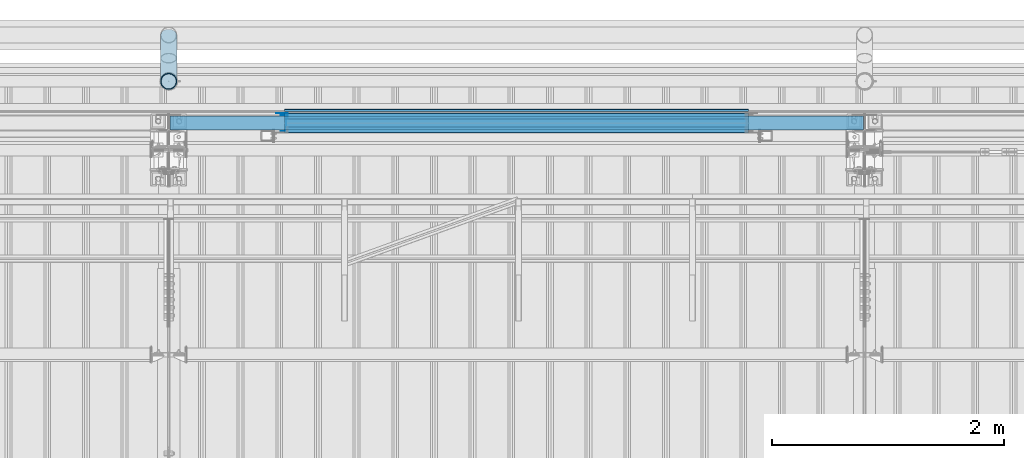
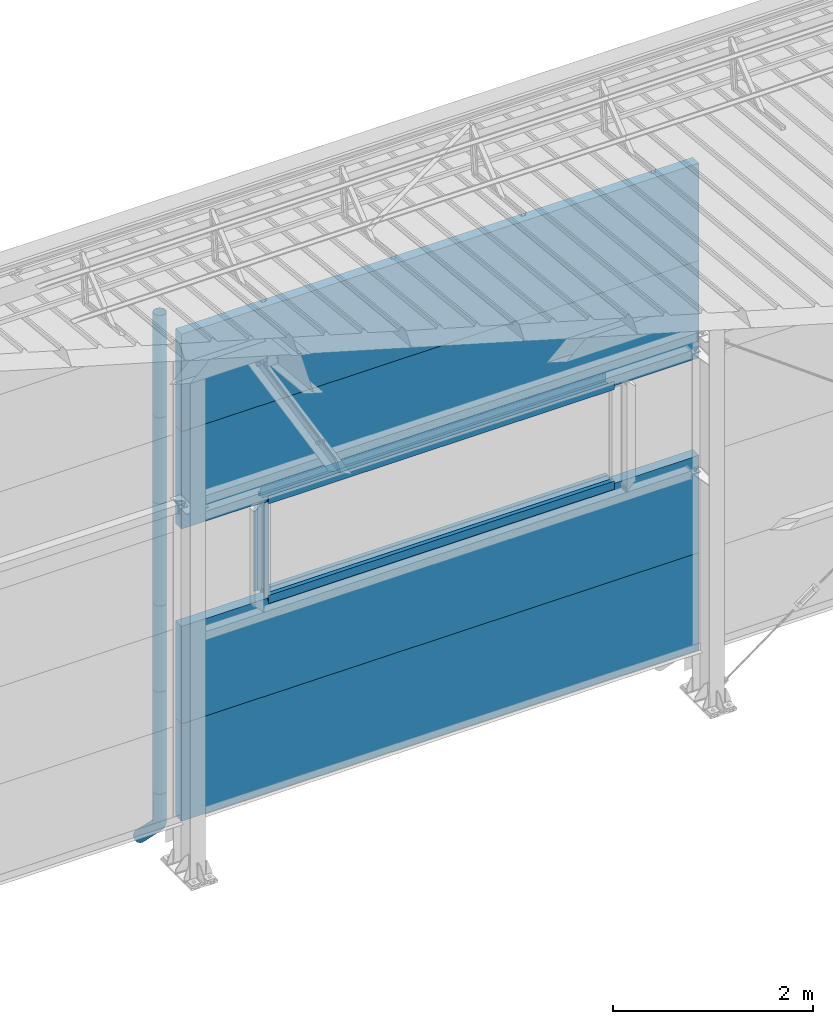
# One storey, part 58 of 709: 19 beams, 19 elements without a shape of their own.
"""IFC4 building model written with IfcOpenShell, lengths in millimetres."""

from ifc_helpers import new_model, entity, si_unit, direction, frame, origin_with_axes, place, context, subcontext, project, spatial, line, indexed_curve, outline, extrude, material, element, aggregate, save


model = new_model("IFC4")

# Units and contexts
model_context = context("Model", 3, precision=0.2, world=origin_with_axes(), true_north=direction((0.0, 1.0)))
body_context = subcontext(model_context, "Body", "Model", "MODEL_VIEW")
ifc_project = project(units=[si_unit("LENGTHUNIT", "METRE", prefix="MILLI"), si_unit("AREAUNIT", "SQUARE_METRE"), si_unit("VOLUMEUNIT", "CUBIC_METRE"), si_unit("MASSUNIT", "GRAM", prefix="KILO"), si_unit("TIMEUNIT", "SECOND"), si_unit("PLANEANGLEUNIT", "RADIAN"), si_unit("SOLIDANGLEUNIT", "STERADIAN"), si_unit("THERMODYNAMICTEMPERATUREUNIT", "DEGREE_CELSIUS"), si_unit("LUMINOUSINTENSITYUNIT", "LUMEN")], contexts=[model_context])

# Site, building, storey
site_placement = place(None, origin_with_axes())
site = spatial("IfcSite", under=ifc_project, at=site_placement, CompositionType="ELEMENT")
building_placement = place(site_placement, origin_with_axes())
building = spatial("IfcBuilding", under=site, at=building_placement, Name="Undefined", CompositionType="ELEMENT")
storey_placement = place(building_placement, origin_with_axes())
storey = spatial("IfcBuildingStorey", under=building, at=storey_placement, Name="Undefined", CompositionType="ELEMENT", Elevation=0.0)

# Assembly, beam
assembly_1_placement = place(storey_placement, frame((16010.0, 22060.0, 895.0), z_axis=(0.0, 0.0, -1.0), x_axis=(1.0, 0.0, 0.0)))
assembly_1 = element("IfcElementAssembly", 1, at=assembly_1_placement, inside=storey)
ifc_material_1 = material(Name="Insulation", Category="Insulation")
beam_1_placement = place(assembly_1_placement, origin_with_axes())
beam_1 = element("IfcBeam", 2, at=beam_1_placement, material=ifc_material_1, ObjectType="P-107", context=body_context, shape_type="SolidModel", body=[
    extrude(outline(indexed_curve([(-595.0, -60.0), (595.0, -60.0), (595.0, 60.0), (-595.0, 60.0)], segments=[line(1, 2, 3, 4, 1)])), frame((0.0, 0.0, 0.0), z_axis=(-1.0, 0.0, 0.0), x_axis=(0.0, 0.0, 1.0)), (0.0, 0.0, -1.0), 5980.0),
])
aggregate(assembly_1, [beam_1])

assembly_2_placement = place(storey_placement, frame((16010.0, 22060.0, 2085.0), z_axis=(0.0, 0.0, -1.0), x_axis=(1.0, 0.0, 0.0)))
assembly_2 = element("IfcElementAssembly", 3, at=assembly_2_placement, inside=storey)
beam_2_placement = place(assembly_2_placement, origin_with_axes())
beam_2 = element("IfcBeam", 4, at=beam_2_placement, material=ifc_material_1, ObjectType="P-107", context=body_context, shape_type="SolidModel", body=[
    extrude(outline(indexed_curve([(-595.0, -60.0), (595.0, -60.0), (595.0, 60.0), (-595.0, 60.0)], segments=[line(1, 2, 3, 4, 1)])), frame((0.0, 0.0, 0.0), z_axis=(-1.0, 0.0, 0.0), x_axis=(0.0, 0.0, 1.0)), (0.0, 0.0, -1.0), 5980.0),
])
aggregate(assembly_2, [beam_2])

assembly_3_placement = place(storey_placement, frame((16010.0, 22060.0, 4465.0), z_axis=(0.0, 0.0, -1.0), x_axis=(1.0, 0.0, 0.0)))
assembly_3 = element("IfcElementAssembly", 5, at=assembly_3_placement, inside=storey)
beam_3_placement = place(assembly_3_placement, origin_with_axes())
beam_3 = element("IfcBeam", 6, at=beam_3_placement, material=ifc_material_1, ObjectType="P-107", context=body_context, shape_type="SolidModel", body=[
    extrude(outline(indexed_curve([(-595.0, -60.0), (595.0, -60.0), (595.0, 60.0), (-595.0, 60.0)], segments=[line(1, 2, 3, 4, 1)])), frame((0.0, 0.0, 0.0), z_axis=(-1.0, 0.0, 0.0), x_axis=(0.0, 0.0, 1.0)), (0.0, 0.0, -1.0), 5980.0),
])
aggregate(assembly_3, [beam_3])

assembly_4_placement = place(storey_placement, frame((16010.0, 22060.0, 5655.0), z_axis=(0.0, 0.0, -1.0), x_axis=(1.0, 0.0, 0.0)))
assembly_4 = element("IfcElementAssembly", 7, at=assembly_4_placement, inside=storey)
beam_4_placement = place(assembly_4_placement, origin_with_axes())
beam_4 = element("IfcBeam", 8, at=beam_4_placement, material=ifc_material_1, ObjectType="P-107", context=body_context, shape_type="SolidModel", body=[
    extrude(outline(indexed_curve([(-595.0, -60.0), (595.0, -60.0), (595.0, 60.0), (-595.0, 60.0)], segments=[line(1, 2, 3, 4, 1)])), frame((0.0, 0.0, 0.0), z_axis=(-1.0, 0.0, 0.0), x_axis=(0.0, 0.0, 1.0)), (0.0, 0.0, -1.0), 5980.0),
])
aggregate(assembly_4, [beam_4])

assembly_5_placement = place(storey_placement, frame((21000.0, 22001.0, 2725.0), z_axis=(0.0, -1.0, 0.0), x_axis=(-1.0, 0.0, 0.0)))
assembly_5 = element("IfcElementAssembly", 9, at=assembly_5_placement, inside=storey)
ifc_material_2 = material(Name="Steel_Undefined", Category="STEEL")
beam_5_placement = place(assembly_5_placement, origin_with_axes())
beam_5 = element("IfcBeam", 10, at=beam_5_placement, material=ifc_material_2, context=body_context, shape_type="SolidModel", body=[
    extrude(outline(indexed_curve([(-25.0, -1.0), (25.0, -1.0), (25.0, 99.0), (23.0, 99.0), (23.0, 1.0), (-25.0, 1.0)], segments=[line(1, 2, 3, 4, 5, 6, 1)])), frame((0.0, 0.0, 0.0), z_axis=(-1.0, 0.0, 0.0), x_axis=(0.0, 0.0, 1.0)), (0.0, 0.0, -1.0), 4000.0),
])
aggregate(assembly_5, [beam_5])

assembly_6_placement = place(storey_placement, frame((21000.0, 22060.0, 2680.0), z_axis=(0.0, 1.0, 0.0), x_axis=(-1.0, 0.0, 0.0)))
assembly_6 = element("IfcElementAssembly", 11, at=assembly_6_placement, inside=storey)
beam_6_placement = place(assembly_6_placement, origin_with_axes())
beam_6 = element("IfcBeam", 12, at=beam_6_placement, material=ifc_material_2, context=body_context, shape_type="SolidModel", body=[
    extrude(outline(indexed_curve([(-70.0, -25.0), (-68.0, -25.0), (-68.0, 23.0), (68.0, 23.0), (68.0, -25.0), (70.0, -25.0), (70.0, 25.0), (-70.0, 25.0)], segments=[line(1, 2, 3, 4, 5, 6, 7, 8, 1)])), frame((0.0, 0.0, 0.0), z_axis=(-1.0, 0.0, 0.0), x_axis=(0.0, 0.0, 1.0)), (0.0, 0.0, -1.0), 4000.0),
])
aggregate(assembly_6, [beam_6])

assembly_7_placement = place(storey_placement, frame((17000.0, 22121.0, 2725.0), z_axis=(0.0, 1.0, 0.0), x_axis=(1.0, 0.0, 0.0)))
assembly_7 = element("IfcElementAssembly", 13, at=assembly_7_placement, inside=storey)
beam_7_placement = place(assembly_7_placement, origin_with_axes())
beam_7 = element("IfcBeam", 14, at=beam_7_placement, material=ifc_material_2, context=body_context, shape_type="SolidModel", body=[
    extrude(outline(indexed_curve([(-25.0, -1.0), (25.0, -1.0), (25.0, 99.0), (23.0, 99.0), (23.0, 1.0), (-25.0, 1.0)], segments=[line(1, 2, 3, 4, 5, 6, 1)])), frame((0.0, 0.0, 0.0), z_axis=(-1.0, 0.0, 0.0), x_axis=(0.0, 0.0, 1.0)), (0.0, 0.0, -1.0), 4000.0),
])
aggregate(assembly_7, [beam_7])

assembly_8_placement = place(storey_placement, frame((17000.0, 22001.0, 3845.0), z_axis=(0.0, -1.0, 0.0), x_axis=(1.0, 0.0, 0.0)))
assembly_8 = element("IfcElementAssembly", 15, at=assembly_8_placement, inside=storey)
beam_8_placement = place(assembly_8_placement, origin_with_axes())
beam_8 = element("IfcBeam", 16, at=beam_8_placement, material=ifc_material_2, context=body_context, shape_type="SolidModel", body=[
    extrude(outline(indexed_curve([(-25.0, -1.0), (25.0, -1.0), (25.0, 99.0), (23.0, 99.0), (23.0, 1.0), (-25.0, 1.0)], segments=[line(1, 2, 3, 4, 5, 6, 1)])), frame((0.0, 0.0, 0.0), z_axis=(-1.0, 0.0, 0.0), x_axis=(0.0, 0.0, 1.0)), (0.0, 0.0, -1.0), 4000.0),
])
aggregate(assembly_8, [beam_8])

assembly_9_placement = place(storey_placement, frame((21000.0, 22060.0, 3890.0), z_axis=(0.0, -1.0, 0.0), x_axis=(-1.0, 0.0, 0.0)))
assembly_9 = element("IfcElementAssembly", 17, at=assembly_9_placement, inside=storey)
beam_9_placement = place(assembly_9_placement, origin_with_axes())
beam_9 = element("IfcBeam", 18, at=beam_9_placement, material=ifc_material_2, context=body_context, shape_type="SolidModel", body=[
    extrude(outline(indexed_curve([(-70.0, -25.0), (-68.0, -25.0), (-68.0, 23.0), (68.0, 23.0), (68.0, -25.0), (70.0, -25.0), (70.0, 25.0), (-70.0, 25.0)], segments=[line(1, 2, 3, 4, 5, 6, 7, 8, 1)])), frame((0.0, 0.0, 0.0), z_axis=(-1.0, 0.0, 0.0), x_axis=(0.0, 0.0, 1.0)), (0.0, 0.0, -1.0), 4000.0),
])
aggregate(assembly_9, [beam_9])

assembly_10_placement = place(storey_placement, frame((21000.0, 22121.0, 3845.0), z_axis=(0.0, 1.0, 0.0), x_axis=(-1.0, 0.0, 0.0)))
assembly_10 = element("IfcElementAssembly", 19, at=assembly_10_placement, inside=storey)
beam_10_placement = place(assembly_10_placement, origin_with_axes())
beam_10 = element("IfcBeam", 20, at=beam_10_placement, material=ifc_material_2, context=body_context, shape_type="SolidModel", body=[
    extrude(outline(indexed_curve([(-25.0, -1.0), (25.0, -1.0), (25.0, 99.0), (23.0, 99.0), (23.0, 1.0), (-25.0, 1.0)], segments=[line(1, 2, 3, 4, 5, 6, 1)])), frame((0.0, 0.0, 0.0), z_axis=(-1.0, 0.0, 0.0), x_axis=(0.0, 0.0, 1.0)), (0.0, 0.0, -1.0), 4000.0),
])
aggregate(assembly_10, [beam_10])

assembly_11_placement = place(storey_placement, frame((21000.0, 22171.0, 3830.0), z_axis=(0.0, 1.0, 0.0), x_axis=(-1.0, 0.0, 0.0)))
assembly_11 = element("IfcElementAssembly", 21, at=assembly_11_placement, inside=storey)
beam_11_placement = place(assembly_11_placement, origin_with_axes())
beam_11 = element("IfcBeam", 22, at=beam_11_placement, material=ifc_material_2, context=body_context, shape_type="SolidModel", body=[
    extrude(outline(indexed_curve([(-10.0, -1.0), (10.0, -1.0), (10.0, 49.0), (8.0, 49.0), (8.0, 1.0), (-10.0, 1.0)], segments=[line(1, 2, 3, 4, 5, 6, 1)])), frame((0.0, 0.0, 0.0), z_axis=(-1.0, 0.0, 0.0), x_axis=(0.0, 0.0, 1.0)), (0.0, 0.0, -1.0), 4000.0),
])
aggregate(assembly_11, [beam_11])

assembly_12_placement = place(storey_placement, frame((16990.0, 22060.0, 3870.0), z_axis=(0.0, -1.0, 0.0), x_axis=(0.0, 0.0, -1.0)))
assembly_12 = element("IfcElementAssembly", 23, at=assembly_12_placement, inside=storey)
beam_12_placement = place(assembly_12_placement, origin_with_axes())
beam_12 = element("IfcBeam", 24, at=beam_12_placement, material=ifc_material_2, context=body_context, shape_type="SolidModel", body=[
    extrude(outline(indexed_curve([(-70.0, -25.0), (-68.0, -25.0), (-68.0, 23.0), (68.0, 23.0), (68.0, -25.0), (70.0, -25.0), (70.0, 25.0), (-70.0, 25.0)], segments=[line(1, 2, 3, 4, 5, 6, 7, 8, 1)])), frame((0.0, 0.0, 0.0), z_axis=(-1.0, 0.0, 0.0), x_axis=(0.0, 0.0, 1.0)), (0.0, 0.0, -1.0), 1170.0),
])
aggregate(assembly_12, [beam_12])

assembly_13_placement = place(storey_placement, frame((17025.0, 22121.0, 3870.0), z_axis=(0.0, 1.0, 0.0), x_axis=(0.0, 0.0, -1.0)))
assembly_13 = element("IfcElementAssembly", 25, at=assembly_13_placement, inside=storey)
beam_13_placement = place(assembly_13_placement, origin_with_axes())
beam_13 = element("IfcBeam", 26, at=beam_13_placement, material=ifc_material_2, context=body_context, shape_type="SolidModel", body=[
    extrude(outline(indexed_curve([(-25.0, -1.0), (25.0, -1.0), (25.0, 99.0), (23.0, 99.0), (23.0, 1.0), (-25.0, 1.0)], segments=[line(1, 2, 3, 4, 5, 6, 1)])), frame((0.0, 0.0, 0.0), z_axis=(-1.0, 0.0, 0.0), x_axis=(0.0, 0.0, 1.0)), (0.0, 0.0, -1.0), 1170.0),
])
aggregate(assembly_13, [beam_13])

assembly_14_placement = place(storey_placement, frame((16000.0, 22420.0, 6276.92297), z_axis=(0.0, -1.0, 0.0), x_axis=(0.0, 0.0, -1.0)))
assembly_14 = element("IfcElementAssembly", 27, at=assembly_14_placement, inside=storey)
beam_14_placement = place(assembly_14_placement, origin_with_axes())
beam_14 = element("IfcBeam", 28, at=beam_14_placement, material=ifc_material_2, ObjectType="614", context=body_context, shape_type="SolidModel", body=[
    extrude(outline(indexed_curve([(70.0, 0.0), (69.61653, 7.31699), (68.47033, 14.55382), (66.57396, 21.63119), (63.94818, 28.47157), (60.62178, 35.0), (56.63119, 41.14497), (52.02014, 46.83914), (46.83914, 52.02014), (41.14497, 56.63119), (35.0, 60.62178), (28.47157, 63.94818), (21.63119, 66.57396), (14.55382, 68.47033), (7.31699, 69.61653), (0.0, 70.0), (-7.31699, 69.61653), (-14.55382, 68.47033), (-21.63119, 66.57396), (-28.47157, 63.94818), (-35.0, 60.62178), (-41.14497, 56.63119), (-46.83914, 52.02014), (-52.02014, 46.83914), (-56.63119, 41.14497), (-60.62178, 35.0), (-63.94818, 28.47157), (-66.57396, 21.63119), (-68.47033, 14.55382), (-69.61653, 7.31699), (-70.0, 0.0), (-69.61653, -7.31699), (-68.47033, -14.55382), (-66.57396, -21.63119), (-63.94818, -28.47157), (-60.62178, -35.0), (-56.63119, -41.14497), (-52.02014, -46.83914), (-46.83914, -52.02014), (-41.14497, -56.63119), (-35.0, -60.62178), (-28.47157, -63.94818), (-21.63119, -66.57396), (-14.55382, -68.47033), (-7.31699, -69.61653), (0.0, -70.0), (7.31699, -69.61653), (14.55382, -68.47033), (21.63119, -66.57396), (28.47157, -63.94818), (35.0, -60.62178), (41.14497, -56.63119), (46.83914, -52.02014), (52.02014, -46.83914), (56.63119, -41.14497), (60.62178, -35.0), (63.94818, -28.47157), (66.57396, -21.63119), (68.47033, -14.55382), (69.61653, -7.31699)], segments=[line(1, 2, 3, 4, 5, 6, 7, 8, 9, 10, 11, 12, 13, 14, 15, 16, 17, 18, 19, 20, 21, 22, 23, 24, 25, 26, 27, 28, 29, 30, 31, 32, 33, 34, 35, 36, 37, 38, 39, 40, 41, 42, 43, 44, 45, 46, 47, 48, 49, 50, 51, 52, 53, 54, 55, 56, 57, 58, 59, 60, 1)]), holes=[indexed_curve([(65.0, 0.0), (64.64392, -6.79435), (63.57959, -13.51426), (61.81867, -20.0861), (59.38045, -26.43788), (56.29165, -32.5), (52.5861, -38.20604), (48.30441, -43.49349), (43.49349, -48.30441), (38.20604, -52.5861), (32.5, -56.29165), (26.43788, -59.38045), (20.0861, -61.81867), (13.51426, -63.57959), (6.79435, -64.64392), (0.0, -65.0), (-6.79435, -64.64392), (-13.51426, -63.57959), (-20.0861, -61.81867), (-26.43788, -59.38045), (-32.5, -56.29165), (-38.20604, -52.5861), (-43.49349, -48.30441), (-48.30441, -43.49349), (-52.5861, -38.20604), (-56.29165, -32.5), (-59.38045, -26.43788), (-61.81867, -20.0861), (-63.57959, -13.51426), (-64.64392, -6.79435), (-65.0, 0.0), (-64.64392, 6.79435), (-63.57959, 13.51426), (-61.81867, 20.0861), (-59.38045, 26.43788), (-56.29165, 32.5), (-52.5861, 38.20604), (-48.30441, 43.49349), (-43.49349, 48.30441), (-38.20604, 52.5861), (-32.5, 56.29165), (-26.43788, 59.38045), (-20.0861, 61.81867), (-13.51426, 63.57959), (-6.79435, 64.64392), (0.0, 65.0), (6.79435, 64.64392), (13.51426, 63.57959), (20.0861, 61.81867), (26.43788, 59.38045), (32.5, 56.29165), (38.20604, 52.5861), (43.49349, 48.30441), (48.30441, 43.49349), (52.5861, 38.20604), (56.29165, 32.5), (59.38045, 26.43788), (61.81867, 20.0861), (63.57959, 13.51426), (64.64392, 6.79435)], segments=[line(1, 2, 3, 4, 5, 6, 7, 8, 9, 10, 11, 12, 13, 14, 15, 16, 17, 18, 19, 20, 21, 22, 23, 24, 25, 26, 27, 28, 29, 30, 31, 32, 33, 34, 35, 36, 37, 38, 39, 40, 41, 42, 43, 44, 45, 46, 47, 48, 49, 50, 51, 52, 53, 54, 55, 56, 57, 58, 59, 60, 1)])]), frame((0.0, 0.0, 0.0), z_axis=(-1.0, 0.0, 0.0), x_axis=(0.0, 0.0, 1.0)), (0.0, 0.0, -1.0), 1250.0),
])
aggregate(assembly_14, [beam_14])

assembly_15_placement = place(storey_placement, frame((16000.0, 22420.0, 5126.92297), z_axis=(0.0, -1.0, 0.0), x_axis=(0.0, 0.0, -1.0)))
assembly_15 = element("IfcElementAssembly", 29, at=assembly_15_placement, inside=storey)
beam_15_placement = place(assembly_15_placement, origin_with_axes())
beam_15 = element("IfcBeam", 30, at=beam_15_placement, material=ifc_material_2, ObjectType="614", context=body_context, shape_type="SolidModel", body=[
    extrude(outline(indexed_curve([(70.0, 0.0), (69.61653, 7.31699), (68.47033, 14.55382), (66.57396, 21.63119), (63.94818, 28.47157), (60.62178, 35.0), (56.63119, 41.14497), (52.02014, 46.83914), (46.83914, 52.02014), (41.14497, 56.63119), (35.0, 60.62178), (28.47157, 63.94818), (21.63119, 66.57396), (14.55382, 68.47033), (7.31699, 69.61653), (0.0, 70.0), (-7.31699, 69.61653), (-14.55382, 68.47033), (-21.63119, 66.57396), (-28.47157, 63.94818), (-35.0, 60.62178), (-41.14497, 56.63119), (-46.83914, 52.02014), (-52.02014, 46.83914), (-56.63119, 41.14497), (-60.62178, 35.0), (-63.94818, 28.47157), (-66.57396, 21.63119), (-68.47033, 14.55382), (-69.61653, 7.31699), (-70.0, 0.0), (-69.61653, -7.31699), (-68.47033, -14.55382), (-66.57396, -21.63119), (-63.94818, -28.47157), (-60.62178, -35.0), (-56.63119, -41.14497), (-52.02014, -46.83914), (-46.83914, -52.02014), (-41.14497, -56.63119), (-35.0, -60.62178), (-28.47157, -63.94818), (-21.63119, -66.57396), (-14.55382, -68.47033), (-7.31699, -69.61653), (0.0, -70.0), (7.31699, -69.61653), (14.55382, -68.47033), (21.63119, -66.57396), (28.47157, -63.94818), (35.0, -60.62178), (41.14497, -56.63119), (46.83914, -52.02014), (52.02014, -46.83914), (56.63119, -41.14497), (60.62178, -35.0), (63.94818, -28.47157), (66.57396, -21.63119), (68.47033, -14.55382), (69.61653, -7.31699)], segments=[line(1, 2, 3, 4, 5, 6, 7, 8, 9, 10, 11, 12, 13, 14, 15, 16, 17, 18, 19, 20, 21, 22, 23, 24, 25, 26, 27, 28, 29, 30, 31, 32, 33, 34, 35, 36, 37, 38, 39, 40, 41, 42, 43, 44, 45, 46, 47, 48, 49, 50, 51, 52, 53, 54, 55, 56, 57, 58, 59, 60, 1)]), holes=[indexed_curve([(65.0, 0.0), (64.64392, -6.79435), (63.57959, -13.51426), (61.81867, -20.0861), (59.38045, -26.43788), (56.29165, -32.5), (52.5861, -38.20604), (48.30441, -43.49349), (43.49349, -48.30441), (38.20604, -52.5861), (32.5, -56.29165), (26.43788, -59.38045), (20.0861, -61.81867), (13.51426, -63.57959), (6.79435, -64.64392), (0.0, -65.0), (-6.79435, -64.64392), (-13.51426, -63.57959), (-20.0861, -61.81867), (-26.43788, -59.38045), (-32.5, -56.29165), (-38.20604, -52.5861), (-43.49349, -48.30441), (-48.30441, -43.49349), (-52.5861, -38.20604), (-56.29165, -32.5), (-59.38045, -26.43788), (-61.81867, -20.0861), (-63.57959, -13.51426), (-64.64392, -6.79435), (-65.0, 0.0), (-64.64392, 6.79435), (-63.57959, 13.51426), (-61.81867, 20.0861), (-59.38045, 26.43788), (-56.29165, 32.5), (-52.5861, 38.20604), (-48.30441, 43.49349), (-43.49349, 48.30441), (-38.20604, 52.5861), (-32.5, 56.29165), (-26.43788, 59.38045), (-20.0861, 61.81867), (-13.51426, 63.57959), (-6.79435, 64.64392), (0.0, 65.0), (6.79435, 64.64392), (13.51426, 63.57959), (20.0861, 61.81867), (26.43788, 59.38045), (32.5, 56.29165), (38.20604, 52.5861), (43.49349, 48.30441), (48.30441, 43.49349), (52.5861, 38.20604), (56.29165, 32.5), (59.38045, 26.43788), (61.81867, 20.0861), (63.57959, 13.51426), (64.64392, 6.79435)], segments=[line(1, 2, 3, 4, 5, 6, 7, 8, 9, 10, 11, 12, 13, 14, 15, 16, 17, 18, 19, 20, 21, 22, 23, 24, 25, 26, 27, 28, 29, 30, 31, 32, 33, 34, 35, 36, 37, 38, 39, 40, 41, 42, 43, 44, 45, 46, 47, 48, 49, 50, 51, 52, 53, 54, 55, 56, 57, 58, 59, 60, 1)])]), frame((0.0, 0.0, 0.0), z_axis=(-1.0, 0.0, 0.0), x_axis=(0.0, 0.0, 1.0)), (0.0, 0.0, -1.0), 1250.0),
])
aggregate(assembly_15, [beam_15])

assembly_16_placement = place(storey_placement, frame((16000.0, 22420.0, 3976.92297), z_axis=(0.0, -1.0, 0.0), x_axis=(0.0, 0.0, -1.0)))
assembly_16 = element("IfcElementAssembly", 31, at=assembly_16_placement, inside=storey)
beam_16_placement = place(assembly_16_placement, origin_with_axes())
beam_16 = element("IfcBeam", 32, at=beam_16_placement, material=ifc_material_2, ObjectType="614", context=body_context, shape_type="SolidModel", body=[
    extrude(outline(indexed_curve([(70.0, 0.0), (69.61653, 7.31699), (68.47033, 14.55382), (66.57396, 21.63119), (63.94818, 28.47157), (60.62178, 35.0), (56.63119, 41.14497), (52.02014, 46.83914), (46.83914, 52.02014), (41.14497, 56.63119), (35.0, 60.62178), (28.47157, 63.94818), (21.63119, 66.57396), (14.55382, 68.47033), (7.31699, 69.61653), (0.0, 70.0), (-7.31699, 69.61653), (-14.55382, 68.47033), (-21.63119, 66.57396), (-28.47157, 63.94818), (-35.0, 60.62178), (-41.14497, 56.63119), (-46.83914, 52.02014), (-52.02014, 46.83914), (-56.63119, 41.14497), (-60.62178, 35.0), (-63.94818, 28.47157), (-66.57396, 21.63119), (-68.47033, 14.55382), (-69.61653, 7.31699), (-70.0, 0.0), (-69.61653, -7.31699), (-68.47033, -14.55382), (-66.57396, -21.63119), (-63.94818, -28.47157), (-60.62178, -35.0), (-56.63119, -41.14497), (-52.02014, -46.83914), (-46.83914, -52.02014), (-41.14497, -56.63119), (-35.0, -60.62178), (-28.47157, -63.94818), (-21.63119, -66.57396), (-14.55382, -68.47033), (-7.31699, -69.61653), (0.0, -70.0), (7.31699, -69.61653), (14.55382, -68.47033), (21.63119, -66.57396), (28.47157, -63.94818), (35.0, -60.62178), (41.14497, -56.63119), (46.83914, -52.02014), (52.02014, -46.83914), (56.63119, -41.14497), (60.62178, -35.0), (63.94818, -28.47157), (66.57396, -21.63119), (68.47033, -14.55382), (69.61653, -7.31699)], segments=[line(1, 2, 3, 4, 5, 6, 7, 8, 9, 10, 11, 12, 13, 14, 15, 16, 17, 18, 19, 20, 21, 22, 23, 24, 25, 26, 27, 28, 29, 30, 31, 32, 33, 34, 35, 36, 37, 38, 39, 40, 41, 42, 43, 44, 45, 46, 47, 48, 49, 50, 51, 52, 53, 54, 55, 56, 57, 58, 59, 60, 1)]), holes=[indexed_curve([(65.0, 0.0), (64.64392, -6.79435), (63.57959, -13.51426), (61.81867, -20.0861), (59.38045, -26.43788), (56.29165, -32.5), (52.5861, -38.20604), (48.30441, -43.49349), (43.49349, -48.30441), (38.20604, -52.5861), (32.5, -56.29165), (26.43788, -59.38045), (20.0861, -61.81867), (13.51426, -63.57959), (6.79435, -64.64392), (0.0, -65.0), (-6.79435, -64.64392), (-13.51426, -63.57959), (-20.0861, -61.81867), (-26.43788, -59.38045), (-32.5, -56.29165), (-38.20604, -52.5861), (-43.49349, -48.30441), (-48.30441, -43.49349), (-52.5861, -38.20604), (-56.29165, -32.5), (-59.38045, -26.43788), (-61.81867, -20.0861), (-63.57959, -13.51426), (-64.64392, -6.79435), (-65.0, 0.0), (-64.64392, 6.79435), (-63.57959, 13.51426), (-61.81867, 20.0861), (-59.38045, 26.43788), (-56.29165, 32.5), (-52.5861, 38.20604), (-48.30441, 43.49349), (-43.49349, 48.30441), (-38.20604, 52.5861), (-32.5, 56.29165), (-26.43788, 59.38045), (-20.0861, 61.81867), (-13.51426, 63.57959), (-6.79435, 64.64392), (0.0, 65.0), (6.79435, 64.64392), (13.51426, 63.57959), (20.0861, 61.81867), (26.43788, 59.38045), (32.5, 56.29165), (38.20604, 52.5861), (43.49349, 48.30441), (48.30441, 43.49349), (52.5861, 38.20604), (56.29165, 32.5), (59.38045, 26.43788), (61.81867, 20.0861), (63.57959, 13.51426), (64.64392, 6.79435)], segments=[line(1, 2, 3, 4, 5, 6, 7, 8, 9, 10, 11, 12, 13, 14, 15, 16, 17, 18, 19, 20, 21, 22, 23, 24, 25, 26, 27, 28, 29, 30, 31, 32, 33, 34, 35, 36, 37, 38, 39, 40, 41, 42, 43, 44, 45, 46, 47, 48, 49, 50, 51, 52, 53, 54, 55, 56, 57, 58, 59, 60, 1)])]), frame((0.0, 0.0, 0.0), z_axis=(-1.0, 0.0, 0.0), x_axis=(0.0, 0.0, 1.0)), (0.0, 0.0, -1.0), 1250.0),
])
aggregate(assembly_16, [beam_16])

assembly_17_placement = place(storey_placement, frame((16000.0, 22420.0, 2826.92297), z_axis=(0.0, -1.0, 0.0), x_axis=(0.0, 0.0, -1.0)))
assembly_17 = element("IfcElementAssembly", 33, at=assembly_17_placement, inside=storey)
beam_17_placement = place(assembly_17_placement, origin_with_axes())
beam_17 = element("IfcBeam", 34, at=beam_17_placement, material=ifc_material_2, ObjectType="614", context=body_context, shape_type="SolidModel", body=[
    extrude(outline(indexed_curve([(70.0, 0.0), (69.61653, 7.31699), (68.47033, 14.55382), (66.57396, 21.63119), (63.94818, 28.47157), (60.62178, 35.0), (56.63119, 41.14497), (52.02014, 46.83914), (46.83914, 52.02014), (41.14497, 56.63119), (35.0, 60.62178), (28.47157, 63.94818), (21.63119, 66.57396), (14.55382, 68.47033), (7.31699, 69.61653), (0.0, 70.0), (-7.31699, 69.61653), (-14.55382, 68.47033), (-21.63119, 66.57396), (-28.47157, 63.94818), (-35.0, 60.62178), (-41.14497, 56.63119), (-46.83914, 52.02014), (-52.02014, 46.83914), (-56.63119, 41.14497), (-60.62178, 35.0), (-63.94818, 28.47157), (-66.57396, 21.63119), (-68.47033, 14.55382), (-69.61653, 7.31699), (-70.0, 0.0), (-69.61653, -7.31699), (-68.47033, -14.55382), (-66.57396, -21.63119), (-63.94818, -28.47157), (-60.62178, -35.0), (-56.63119, -41.14497), (-52.02014, -46.83914), (-46.83914, -52.02014), (-41.14497, -56.63119), (-35.0, -60.62178), (-28.47157, -63.94818), (-21.63119, -66.57396), (-14.55382, -68.47033), (-7.31699, -69.61653), (0.0, -70.0), (7.31699, -69.61653), (14.55382, -68.47033), (21.63119, -66.57396), (28.47157, -63.94818), (35.0, -60.62178), (41.14497, -56.63119), (46.83914, -52.02014), (52.02014, -46.83914), (56.63119, -41.14497), (60.62178, -35.0), (63.94818, -28.47157), (66.57396, -21.63119), (68.47033, -14.55382), (69.61653, -7.31699)], segments=[line(1, 2, 3, 4, 5, 6, 7, 8, 9, 10, 11, 12, 13, 14, 15, 16, 17, 18, 19, 20, 21, 22, 23, 24, 25, 26, 27, 28, 29, 30, 31, 32, 33, 34, 35, 36, 37, 38, 39, 40, 41, 42, 43, 44, 45, 46, 47, 48, 49, 50, 51, 52, 53, 54, 55, 56, 57, 58, 59, 60, 1)]), holes=[indexed_curve([(65.0, 0.0), (64.64392, -6.79435), (63.57959, -13.51426), (61.81867, -20.0861), (59.38045, -26.43788), (56.29165, -32.5), (52.5861, -38.20604), (48.30441, -43.49349), (43.49349, -48.30441), (38.20604, -52.5861), (32.5, -56.29165), (26.43788, -59.38045), (20.0861, -61.81867), (13.51426, -63.57959), (6.79435, -64.64392), (0.0, -65.0), (-6.79435, -64.64392), (-13.51426, -63.57959), (-20.0861, -61.81867), (-26.43788, -59.38045), (-32.5, -56.29165), (-38.20604, -52.5861), (-43.49349, -48.30441), (-48.30441, -43.49349), (-52.5861, -38.20604), (-56.29165, -32.5), (-59.38045, -26.43788), (-61.81867, -20.0861), (-63.57959, -13.51426), (-64.64392, -6.79435), (-65.0, 0.0), (-64.64392, 6.79435), (-63.57959, 13.51426), (-61.81867, 20.0861), (-59.38045, 26.43788), (-56.29165, 32.5), (-52.5861, 38.20604), (-48.30441, 43.49349), (-43.49349, 48.30441), (-38.20604, 52.5861), (-32.5, 56.29165), (-26.43788, 59.38045), (-20.0861, 61.81867), (-13.51426, 63.57959), (-6.79435, 64.64392), (0.0, 65.0), (6.79435, 64.64392), (13.51426, 63.57959), (20.0861, 61.81867), (26.43788, 59.38045), (32.5, 56.29165), (38.20604, 52.5861), (43.49349, 48.30441), (48.30441, 43.49349), (52.5861, 38.20604), (56.29165, 32.5), (59.38045, 26.43788), (61.81867, 20.0861), (63.57959, 13.51426), (64.64392, 6.79435)], segments=[line(1, 2, 3, 4, 5, 6, 7, 8, 9, 10, 11, 12, 13, 14, 15, 16, 17, 18, 19, 20, 21, 22, 23, 24, 25, 26, 27, 28, 29, 30, 31, 32, 33, 34, 35, 36, 37, 38, 39, 40, 41, 42, 43, 44, 45, 46, 47, 48, 49, 50, 51, 52, 53, 54, 55, 56, 57, 58, 59, 60, 1)])]), frame((0.0, 0.0, 0.0), z_axis=(-1.0, 0.0, 0.0), x_axis=(0.0, 0.0, 1.0)), (0.0, 0.0, -1.0), 1250.0),
])
aggregate(assembly_17, [beam_17])

assembly_18_placement = place(storey_placement, frame((16000.0, 22420.0, 1676.92297), z_axis=(0.0, -1.0, 0.0), x_axis=(0.0, 0.0, -1.0)))
assembly_18 = element("IfcElementAssembly", 35, at=assembly_18_placement, inside=storey)
beam_18_placement = place(assembly_18_placement, origin_with_axes())
beam_18 = element("IfcBeam", 36, at=beam_18_placement, material=ifc_material_2, ObjectType="614", context=body_context, shape_type="SolidModel", body=[
    extrude(outline(indexed_curve([(70.0, 0.0), (69.61653, 7.31699), (68.47033, 14.55382), (66.57396, 21.63119), (63.94818, 28.47157), (60.62178, 35.0), (56.63119, 41.14497), (52.02014, 46.83914), (46.83914, 52.02014), (41.14497, 56.63119), (35.0, 60.62178), (28.47157, 63.94818), (21.63119, 66.57396), (14.55382, 68.47033), (7.31699, 69.61653), (0.0, 70.0), (-7.31699, 69.61653), (-14.55382, 68.47033), (-21.63119, 66.57396), (-28.47157, 63.94818), (-35.0, 60.62178), (-41.14497, 56.63119), (-46.83914, 52.02014), (-52.02014, 46.83914), (-56.63119, 41.14497), (-60.62178, 35.0), (-63.94818, 28.47157), (-66.57396, 21.63119), (-68.47033, 14.55382), (-69.61653, 7.31699), (-70.0, 0.0), (-69.61653, -7.31699), (-68.47033, -14.55382), (-66.57396, -21.63119), (-63.94818, -28.47157), (-60.62178, -35.0), (-56.63119, -41.14497), (-52.02014, -46.83914), (-46.83914, -52.02014), (-41.14497, -56.63119), (-35.0, -60.62178), (-28.47157, -63.94818), (-21.63119, -66.57396), (-14.55382, -68.47033), (-7.31699, -69.61653), (0.0, -70.0), (7.31699, -69.61653), (14.55382, -68.47033), (21.63119, -66.57396), (28.47157, -63.94818), (35.0, -60.62178), (41.14497, -56.63119), (46.83914, -52.02014), (52.02014, -46.83914), (56.63119, -41.14497), (60.62178, -35.0), (63.94818, -28.47157), (66.57396, -21.63119), (68.47033, -14.55382), (69.61653, -7.31699)], segments=[line(1, 2, 3, 4, 5, 6, 7, 8, 9, 10, 11, 12, 13, 14, 15, 16, 17, 18, 19, 20, 21, 22, 23, 24, 25, 26, 27, 28, 29, 30, 31, 32, 33, 34, 35, 36, 37, 38, 39, 40, 41, 42, 43, 44, 45, 46, 47, 48, 49, 50, 51, 52, 53, 54, 55, 56, 57, 58, 59, 60, 1)]), holes=[indexed_curve([(65.0, 0.0), (64.64392, -6.79435), (63.57959, -13.51426), (61.81867, -20.0861), (59.38045, -26.43788), (56.29165, -32.5), (52.5861, -38.20604), (48.30441, -43.49349), (43.49349, -48.30441), (38.20604, -52.5861), (32.5, -56.29165), (26.43788, -59.38045), (20.0861, -61.81867), (13.51426, -63.57959), (6.79435, -64.64392), (0.0, -65.0), (-6.79435, -64.64392), (-13.51426, -63.57959), (-20.0861, -61.81867), (-26.43788, -59.38045), (-32.5, -56.29165), (-38.20604, -52.5861), (-43.49349, -48.30441), (-48.30441, -43.49349), (-52.5861, -38.20604), (-56.29165, -32.5), (-59.38045, -26.43788), (-61.81867, -20.0861), (-63.57959, -13.51426), (-64.64392, -6.79435), (-65.0, 0.0), (-64.64392, 6.79435), (-63.57959, 13.51426), (-61.81867, 20.0861), (-59.38045, 26.43788), (-56.29165, 32.5), (-52.5861, 38.20604), (-48.30441, 43.49349), (-43.49349, 48.30441), (-38.20604, 52.5861), (-32.5, 56.29165), (-26.43788, 59.38045), (-20.0861, 61.81867), (-13.51426, 63.57959), (-6.79435, 64.64392), (0.0, 65.0), (6.79435, 64.64392), (13.51426, 63.57959), (20.0861, 61.81867), (26.43788, 59.38045), (32.5, 56.29165), (38.20604, 52.5861), (43.49349, 48.30441), (48.30441, 43.49349), (52.5861, 38.20604), (56.29165, 32.5), (59.38045, 26.43788), (61.81867, 20.0861), (63.57959, 13.51426), (64.64392, 6.79435)], segments=[line(1, 2, 3, 4, 5, 6, 7, 8, 9, 10, 11, 12, 13, 14, 15, 16, 17, 18, 19, 20, 21, 22, 23, 24, 25, 26, 27, 28, 29, 30, 31, 32, 33, 34, 35, 36, 37, 38, 39, 40, 41, 42, 43, 44, 45, 46, 47, 48, 49, 50, 51, 52, 53, 54, 55, 56, 57, 58, 59, 60, 1)])]), frame((0.0, 0.0, 0.0), z_axis=(-1.0, 0.0, 0.0), x_axis=(0.0, 0.0, 1.0)), (0.0, 0.0, -1.0), 1250.0),
])
aggregate(assembly_18, [beam_18])

assembly_19_placement = place(storey_placement, frame((16000.0, 22420.0, 526.92297), z_axis=(1.0, 0.0, 0.0), x_axis=(0.0, 0.0, -1.0)))
assembly_19 = element("IfcElementAssembly", 37, at=assembly_19_placement, inside=storey)
beam_19_placement = place(assembly_19_placement, origin_with_axes())
beam_19 = element("IfcBeam", 38, at=beam_19_placement, material=ifc_material_2, ObjectType="617", context=body_context, shape_type="SolidModel", body=[
    entity("IfcSweptDiskSolid", entity("IfcIndexedPolyCurve", entity("IfcCartesianPointList3D", [[0.0, 0.0, 0.0], [448.2233, 0.0, 0.0], [496.05873, 9.51506, 0.0], [536.61165, 36.61165, 0.0], [900.0, 400.0, 0.0]]), [entity("IfcLineIndex", [1, 2]), entity("IfcArcIndex", [2, 3, 4]), entity("IfcLineIndex", [4, 5])]), 70.0, 65.0),
])
aggregate(assembly_19, [beam_19])

save(model, "model.ifc")
